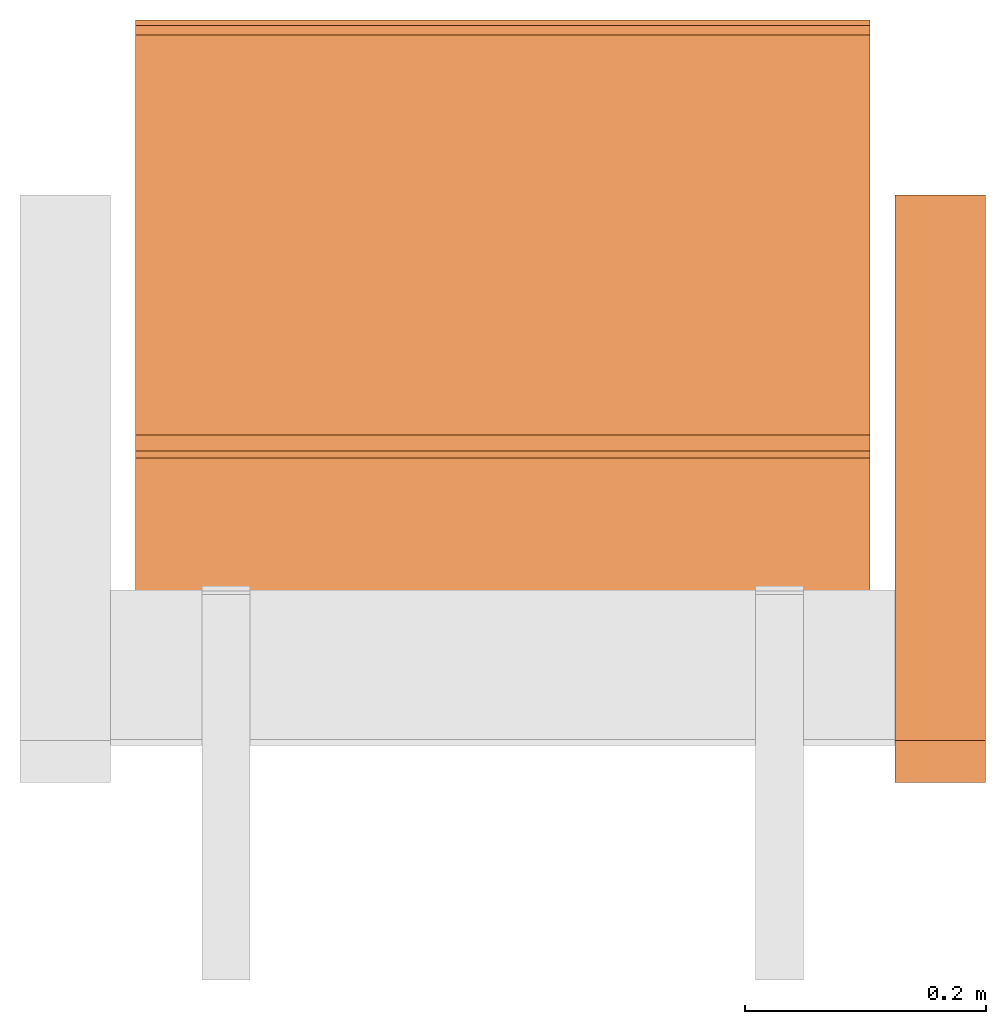
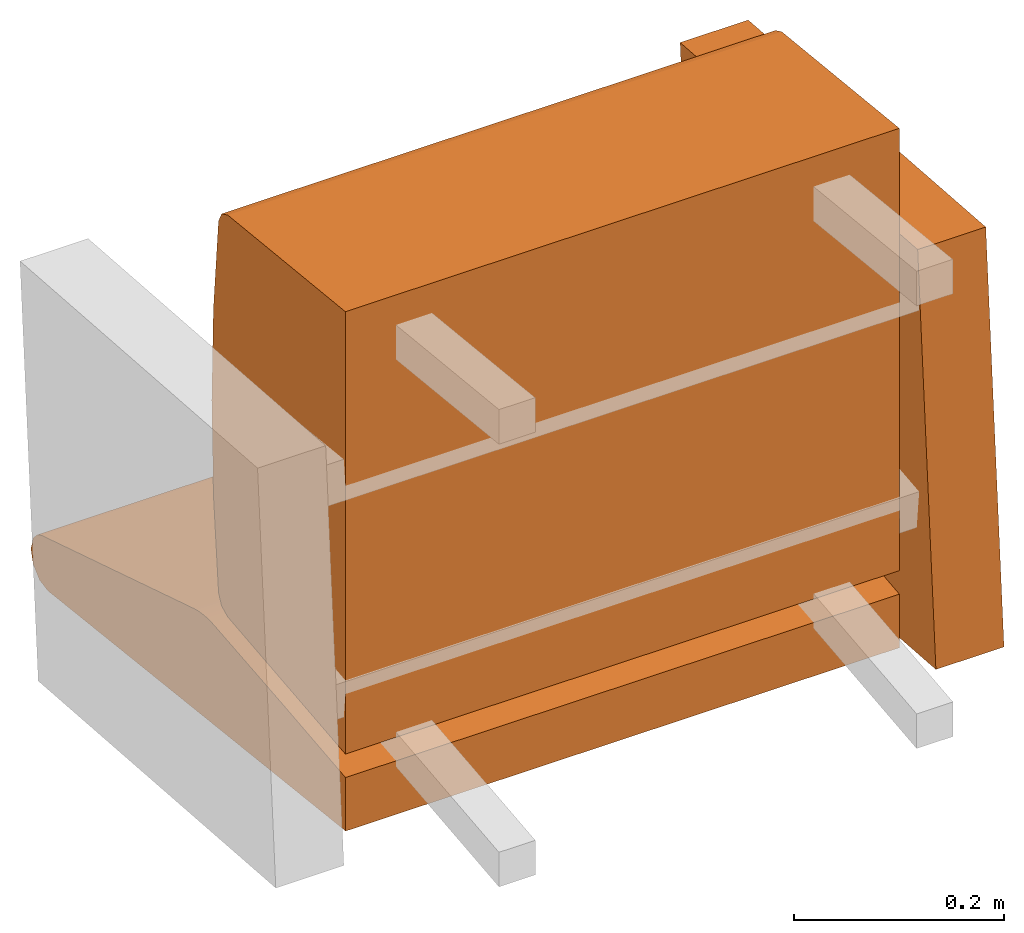
# One storey, part 1 of 2: 3 proxies, 1 element without a shape of its own.
"""IFC2X3 building model written with IfcOpenShell, lengths in metres."""

from ifc_helpers import new_model, si_unit, direction, origin_with_axes, place, context, project, spatial, faceted_brep, source, transform, mapped, element, aggregate, save


model = new_model("IFC2X3")

# Units and contexts
model_context = context("Model", 3, precision=1e-06, world=origin_with_axes(), true_north=direction((0.0, 1.0, 0.0)))
ifc_project = project(units=[si_unit("LENGTHUNIT", "METRE"), si_unit("AREAUNIT", "SQUARE_METRE"), si_unit("VOLUMEUNIT", "CUBIC_METRE")], contexts=[model_context])

# Site, building, storey
site_placement = place(None, origin_with_axes())
site = spatial("IfcSite", under=ifc_project, at=site_placement, CompositionType="ELEMENT")
building_placement = place(site_placement, origin_with_axes())
building = spatial("IfcBuilding", under=site, at=building_placement, Name="Default Building", CompositionType="ELEMENT")
storey_placement = place(building_placement, origin_with_axes())
storey = spatial("IfcBuildingStorey", under=building, at=storey_placement, Name="Default Storey", CompositionType="ELEMENT", Elevation=0.0)

# Assembly, proxies
assembly_placement = place(storey_placement, origin_with_axes())
assembly = element("IfcElementAssembly", 1, at=assembly_placement, inside=storey, Name="H-04-063-A_1-seater", ObjectType="H-04-063-A_1-seater", AssemblyPlace="NOTDEFINED", PredefinedType="NOTDEFINED")
shared_shape_1 = source(origin_with_axes(), model_context, "Body", "Brep", [
    faceted_brep([(0.3050000071525574, 0.14325888454914093, -0.2591053545475006), (0.3050000071525574, 0.1481551080942154, -0.25895237922668457), (-0.3050000071525574, 0.14325888454914093, -0.2591053545475006), (-0.3050000071525574, 0.14325888454914093, -0.2591053545475006), (0.3050000071525574, 0.1481551080942154, -0.25895237922668457), (-0.3050000071525574, 0.1481551080942154, -0.25895237922668457), (0.3050000071525574, 0.13837602734565735, -0.2594979405403137), (0.3050000071525574, 0.14325888454914093, -0.2591053545475006), (-0.3050000071525574, 0.13837602734565735, -0.2594979405403137), (-0.3050000071525574, 0.13837602734565735, -0.2594979405403137), (0.3050000071525574, 0.14325888454914093, -0.2591053545475006), (-0.3050000071525574, 0.14325888454914093, -0.2591053545475006), (0.3050000071525574, 0.01806718483567238, -0.27113938331604004), (0.3050000071525574, 0.13837602734565735, -0.2594979405403137), (-0.3050000071525574, 0.01806718483567238, -0.27113938331604004), (-0.3050000071525574, 0.01806718483567238, -0.27113938331604004), (0.3050000071525574, 0.13837602734565735, -0.2594979405403137), (-0.3050000071525574, 0.13837602734565735, -0.2594979405403137), (0.3050000071525574, -0.11122065782546997, -0.28472810983657837), (0.3050000071525574, 0.01806718483567238, -0.27113938331604004), (-0.3050000071525574, -0.11122065782546997, -0.28472810983657837), (-0.3050000071525574, -0.11122065782546997, -0.28472810983657837), (0.3050000071525574, 0.01806718483567238, -0.27113938331604004), (-0.3050000071525574, 0.01806718483567238, -0.27113938331604004), (0.3050000071525574, -0.11149738729000092, -0.34173157811164856), (0.3050000071525574, -0.11122065782546997, -0.28472810983657837), (-0.3050000071525574, -0.11149738729000092, -0.34173157811164856), (-0.3050000071525574, -0.11149738729000092, -0.34173157811164856), (0.3050000071525574, -0.11122065782546997, -0.28472810983657837), (-0.3050000071525574, -0.11122065782546997, -0.28472810983657837), (0.3050000071525574, -0.11152229458093643, -0.34686172008514404), (0.3050000071525574, -0.11149738729000092, -0.34173157811164856), (-0.3050000071525574, -0.11152229458093643, -0.34686172008514404), (-0.3050000071525574, -0.11152229458093643, -0.34686172008514404), (0.3050000071525574, -0.11149738729000092, -0.34173157811164856), (-0.3050000071525574, -0.11149738729000092, -0.34173157811164856), (0.3050000071525574, 0.45688581466674805, -0.41162365674972534), (0.3050000071525574, -0.11152229458093643, -0.34686172008514404), (-0.3050000071525574, 0.45688581466674805, -0.41162365674972534), (-0.3050000071525574, 0.45688581466674805, -0.41162365674972534), (0.3050000071525574, -0.11152229458093643, -0.34686172008514404), (-0.3050000071525574, -0.11152229458093643, -0.34686172008514404), (0.3050000071525574, 0.47266271710395813, -0.4085805416107178), (0.3050000071525574, 0.45688581466674805, -0.41162365674972534), (-0.3050000071525574, 0.47266271710395813, -0.4085805416107178), (-0.3050000071525574, 0.47266271710395813, -0.4085805416107178), (0.3050000071525574, 0.45688581466674805, -0.41162365674972534), (-0.3050000071525574, 0.45688581466674805, -0.41162365674972534), (0.3050000071525574, 0.48450586199760437, -0.3977386951446533), (0.3050000071525574, 0.47266271710395813, -0.4085805416107178), (-0.3050000071525574, 0.48450586199760437, -0.3977386951446533), (-0.3050000071525574, 0.48450586199760437, -0.3977386951446533), (0.3050000071525574, 0.47266271710395813, -0.4085805416107178), (-0.3050000071525574, 0.47266271710395813, -0.4085805416107178), (0.3050000071525574, 0.4888891279697418, -0.382292240858078), (0.3050000071525574, 0.48450586199760437, -0.3977386951446533), (-0.3050000071525574, 0.4888891279697418, -0.382292240858078), (-0.3050000071525574, 0.4888891279697418, -0.382292240858078), (0.3050000071525574, 0.48450586199760437, -0.3977386951446533), (-0.3050000071525574, 0.48450586199760437, -0.3977386951446533), (0.3050000071525574, 0.48450586199760437, -0.3668457865715027), (0.3050000071525574, 0.4888891279697418, -0.382292240858078), (-0.3050000071525574, 0.48450586199760437, -0.3668457865715027), (-0.3050000071525574, 0.48450586199760437, -0.3668457865715027), (0.3050000071525574, 0.4888891279697418, -0.382292240858078), (-0.3050000071525574, 0.4888891279697418, -0.382292240858078), (0.3050000071525574, 0.48142513632774353, -0.36358898878097534), (0.3050000071525574, 0.48450586199760437, -0.3668457865715027), (-0.3050000071525574, 0.48142513632774353, -0.36358898878097534), (-0.3050000071525574, 0.48142513632774353, -0.36358898878097534), (0.3050000071525574, 0.48450586199760437, -0.3668457865715027), (-0.3050000071525574, 0.48450586199760437, -0.3668457865715027), (0.3050000071525574, 0.47629326581954956, -0.3581638038158417), (0.3050000071525574, 0.48142513632774353, -0.36358898878097534), (-0.3050000071525574, 0.47629326581954956, -0.3581638038158417), (-0.3050000071525574, 0.47629326581954956, -0.3581638038158417), (0.3050000071525574, 0.48142513632774353, -0.36358898878097534), (-0.3050000071525574, 0.48142513632774353, -0.36358898878097534), (0.3050000071525574, 0.46827244758605957, -0.3542290925979614), (0.3050000071525574, 0.47629326581954956, -0.3581638038158417), (-0.3050000071525574, 0.46827244758605957, -0.3542290925979614), (-0.3050000071525574, 0.46827244758605957, -0.3542290925979614), (0.3050000071525574, 0.47629326581954956, -0.3581638038158417), (-0.3050000071525574, 0.47629326581954956, -0.3581638038158417), (0.3050000071525574, 0.17872300744056702, -0.2635229825973511), (0.3050000071525574, 0.46827244758605957, -0.3542290925979614), (-0.3050000071525574, 0.17872300744056702, -0.2635229825973511), (-0.3050000071525574, 0.17872300744056702, -0.2635229825973511), (0.3050000071525574, 0.46827244758605957, -0.3542290925979614), (-0.3050000071525574, 0.46827244758605957, -0.3542290925979614), (0.3050000071525574, 0.1771564930677414, -0.2630462944507599), (0.3050000071525574, 0.17872300744056702, -0.2635229825973511), (-0.3050000071525574, 0.1771564930677414, -0.2630462944507599), (-0.3050000071525574, 0.1771564930677414, -0.2630462944507599), (0.3050000071525574, 0.17872300744056702, -0.2635229825973511), (-0.3050000071525574, 0.17872300744056702, -0.2635229825973511), (0.3050000071525574, 0.17242595553398132, -0.26177409291267395), (0.3050000071525574, 0.1771564930677414, -0.2630462944507599), (-0.3050000071525574, 0.17242595553398132, -0.26177409291267395), (-0.3050000071525574, 0.17242595553398132, -0.26177409291267395), (0.3050000071525574, 0.1771564930677414, -0.2630462944507599), (-0.3050000071525574, 0.1771564930677414, -0.2630462944507599), (0.3050000071525574, 0.16763879358768463, -0.2607351243495941), (0.3050000071525574, 0.17242595553398132, -0.26177409291267395), (-0.3050000071525574, 0.16763879358768463, -0.2607351243495941), (-0.3050000071525574, 0.16763879358768463, -0.2607351243495941), (0.3050000071525574, 0.17242595553398132, -0.26177409291267395), (-0.3050000071525574, 0.17242595553398132, -0.26177409291267395), (0.3050000071525574, 0.16280649602413177, -0.2599318027496338), (0.3050000071525574, 0.16763879358768463, -0.2607351243495941), (-0.3050000071525574, 0.16280649602413177, -0.2599318027496338), (-0.3050000071525574, 0.16280649602413177, -0.2599318027496338), (0.3050000071525574, 0.16763879358768463, -0.2607351243495941), (-0.3050000071525574, 0.16763879358768463, -0.2607351243495941), (0.3050000071525574, 0.15794065594673157, -0.25936612486839294), (0.3050000071525574, 0.16280649602413177, -0.2599318027496338), (-0.3050000071525574, 0.15794065594673157, -0.25936612486839294), (-0.3050000071525574, 0.15794065594673157, -0.25936612486839294), (0.3050000071525574, 0.16280649602413177, -0.2599318027496338), (-0.3050000071525574, 0.16280649602413177, -0.2599318027496338), (0.3050000071525574, 0.15305295586585999, -0.25903937220573425), (0.3050000071525574, 0.15794065594673157, -0.25936612486839294), (-0.3050000071525574, 0.15305295586585999, -0.25903937220573425), (-0.3050000071525574, 0.15305295586585999, -0.25903937220573425), (0.3050000071525574, 0.15794065594673157, -0.25936612486839294), (-0.3050000071525574, 0.15794065594673157, -0.25936612486839294), (0.3050000071525574, 0.1481551080942154, -0.25895237922668457), (0.3050000071525574, 0.15305295586585999, -0.25903937220573425), (-0.3050000071525574, 0.1481551080942154, -0.25895237922668457), (-0.3050000071525574, 0.1481551080942154, -0.25895237922668457), (0.3050000071525574, 0.15305295586585999, -0.25903937220573425), (-0.3050000071525574, 0.15305295586585999, -0.25903937220573425), (0.3050000071525574, 0.48450586199760437, -0.3977386951446533), (0.3050000071525574, 0.4888891279697418, -0.382292240858078), (0.3050000071525574, 0.47266271710395813, -0.4085805416107178), (0.3050000071525574, 0.47266271710395813, -0.4085805416107178), (0.3050000071525574, 0.4888891279697418, -0.382292240858078), (0.3050000071525574, 0.48450586199760437, -0.3668457865715027), (0.3050000071525574, 0.47266271710395813, -0.4085805416107178), (0.3050000071525574, 0.48450586199760437, -0.3668457865715027), (0.3050000071525574, 0.45688581466674805, -0.41162365674972534), (0.3050000071525574, 0.45688581466674805, -0.41162365674972534), (0.3050000071525574, 0.48450586199760437, -0.3668457865715027), (0.3050000071525574, 0.48142513632774353, -0.36358898878097534), (0.3050000071525574, 0.14325888454914093, -0.2591053545475006), (0.3050000071525574, 0.13837602734565735, -0.2594979405403137), (0.3050000071525574, -0.11149738729000092, -0.34173157811164856), (0.3050000071525574, -0.11149738729000092, -0.34173157811164856), (0.3050000071525574, 0.13837602734565735, -0.2594979405403137), (0.3050000071525574, 0.01806718483567238, -0.27113938331604004), (0.3050000071525574, -0.11149738729000092, -0.34173157811164856), (0.3050000071525574, 0.01806718483567238, -0.27113938331604004), (0.3050000071525574, -0.11122065782546997, -0.28472810983657837), (0.3050000071525574, -0.11149738729000092, -0.34173157811164856), (0.3050000071525574, -0.11152229458093643, -0.34686172008514404), (0.3050000071525574, 0.46827244758605957, -0.3542290925979614), (0.3050000071525574, 0.46827244758605957, -0.3542290925979614), (0.3050000071525574, -0.11152229458093643, -0.34686172008514404), (0.3050000071525574, 0.45688581466674805, -0.41162365674972534), (0.3050000071525574, 0.46827244758605957, -0.3542290925979614), (0.3050000071525574, 0.45688581466674805, -0.41162365674972534), (0.3050000071525574, 0.47629326581954956, -0.3581638038158417), (0.3050000071525574, 0.47629326581954956, -0.3581638038158417), (0.3050000071525574, 0.45688581466674805, -0.41162365674972534), (0.3050000071525574, 0.48142513632774353, -0.36358898878097534), (0.3050000071525574, 0.46827244758605957, -0.3542290925979614), (0.3050000071525574, 0.17872300744056702, -0.2635229825973511), (0.3050000071525574, -0.11149738729000092, -0.34173157811164856), (0.3050000071525574, -0.11149738729000092, -0.34173157811164856), (0.3050000071525574, 0.17872300744056702, -0.2635229825973511), (0.3050000071525574, 0.1771564930677414, -0.2630462944507599), (0.3050000071525574, -0.11149738729000092, -0.34173157811164856), (0.3050000071525574, 0.1771564930677414, -0.2630462944507599), (0.3050000071525574, 0.17242595553398132, -0.26177409291267395), (0.3050000071525574, 0.17242595553398132, -0.26177409291267395), (0.3050000071525574, 0.16763879358768463, -0.2607351243495941), (0.3050000071525574, -0.11149738729000092, -0.34173157811164856), (0.3050000071525574, -0.11149738729000092, -0.34173157811164856), (0.3050000071525574, 0.16763879358768463, -0.2607351243495941), (0.3050000071525574, 0.16280649602413177, -0.2599318027496338), (0.3050000071525574, -0.11149738729000092, -0.34173157811164856), (0.3050000071525574, 0.16280649602413177, -0.2599318027496338), (0.3050000071525574, 0.15794065594673157, -0.25936612486839294), (0.3050000071525574, 0.15794065594673157, -0.25936612486839294), (0.3050000071525574, 0.15305295586585999, -0.25903937220573425), (0.3050000071525574, -0.11149738729000092, -0.34173157811164856), (0.3050000071525574, -0.11149738729000092, -0.34173157811164856), (0.3050000071525574, 0.15305295586585999, -0.25903937220573425), (0.3050000071525574, 0.1481551080942154, -0.25895237922668457), (0.3050000071525574, -0.11149738729000092, -0.34173157811164856), (0.3050000071525574, 0.1481551080942154, -0.25895237922668457), (0.3050000071525574, 0.14325888454914093, -0.2591053545475006), (-0.3050000071525574, 0.48450586199760437, -0.3668457865715027), (-0.3050000071525574, 0.4888891279697418, -0.382292240858078), (-0.3050000071525574, 0.48450586199760437, -0.3977386951446533), (-0.3050000071525574, 0.47629326581954956, -0.3581638038158417), (-0.3050000071525574, 0.45688581466674805, -0.41162365674972534), (-0.3050000071525574, 0.46827244758605957, -0.3542290925979614), (-0.3050000071525574, 0.46827244758605957, -0.3542290925979614), (-0.3050000071525574, 0.45688581466674805, -0.41162365674972534), (-0.3050000071525574, -0.11152229458093643, -0.34686172008514404), (-0.3050000071525574, 0.46827244758605957, -0.3542290925979614), (-0.3050000071525574, -0.11152229458093643, -0.34686172008514404), (-0.3050000071525574, -0.11149738729000092, -0.34173157811164856), (-0.3050000071525574, 0.47629326581954956, -0.3581638038158417), (-0.3050000071525574, 0.48142513632774353, -0.36358898878097534), (-0.3050000071525574, 0.45688581466674805, -0.41162365674972534), (-0.3050000071525574, 0.45688581466674805, -0.41162365674972534), (-0.3050000071525574, 0.48142513632774353, -0.36358898878097534), (-0.3050000071525574, 0.48450586199760437, -0.3668457865715027), (-0.3050000071525574, 0.45688581466674805, -0.41162365674972534), (-0.3050000071525574, 0.48450586199760437, -0.3668457865715027), (-0.3050000071525574, 0.47266271710395813, -0.4085805416107178), (-0.3050000071525574, 0.47266271710395813, -0.4085805416107178), (-0.3050000071525574, 0.48450586199760437, -0.3668457865715027), (-0.3050000071525574, 0.48450586199760437, -0.3977386951446533), (-0.3050000071525574, 0.17242595553398132, -0.26177409291267395), (-0.3050000071525574, 0.1771564930677414, -0.2630462944507599), (-0.3050000071525574, -0.11149738729000092, -0.34173157811164856), (-0.3050000071525574, -0.11149738729000092, -0.34173157811164856), (-0.3050000071525574, 0.1771564930677414, -0.2630462944507599), (-0.3050000071525574, 0.17872300744056702, -0.2635229825973511), (-0.3050000071525574, -0.11149738729000092, -0.34173157811164856), (-0.3050000071525574, 0.17872300744056702, -0.2635229825973511), (-0.3050000071525574, 0.46827244758605957, -0.3542290925979614), (-0.3050000071525574, -0.11122065782546997, -0.28472810983657837), (-0.3050000071525574, 0.01806718483567238, -0.27113938331604004), (-0.3050000071525574, -0.11149738729000092, -0.34173157811164856), (-0.3050000071525574, -0.11149738729000092, -0.34173157811164856), (-0.3050000071525574, 0.01806718483567238, -0.27113938331604004), (-0.3050000071525574, 0.13837602734565735, -0.2594979405403137), (-0.3050000071525574, -0.11149738729000092, -0.34173157811164856), (-0.3050000071525574, 0.13837602734565735, -0.2594979405403137), (-0.3050000071525574, 0.14325888454914093, -0.2591053545475006), (-0.3050000071525574, 0.14325888454914093, -0.2591053545475006), (-0.3050000071525574, 0.1481551080942154, -0.25895237922668457), (-0.3050000071525574, -0.11149738729000092, -0.34173157811164856), (-0.3050000071525574, -0.11149738729000092, -0.34173157811164856), (-0.3050000071525574, 0.1481551080942154, -0.25895237922668457), (-0.3050000071525574, 0.15305295586585999, -0.25903937220573425), (-0.3050000071525574, -0.11149738729000092, -0.34173157811164856), (-0.3050000071525574, 0.15305295586585999, -0.25903937220573425), (-0.3050000071525574, 0.15794065594673157, -0.25936612486839294), (-0.3050000071525574, 0.15794065594673157, -0.25936612486839294), (-0.3050000071525574, 0.16280649602413177, -0.2599318027496338), (-0.3050000071525574, -0.11149738729000092, -0.34173157811164856), (-0.3050000071525574, -0.11149738729000092, -0.34173157811164856), (-0.3050000071525574, 0.16280649602413177, -0.2599318027496338), (-0.3050000071525574, 0.16763879358768463, -0.2607351243495941), (-0.3050000071525574, -0.11149738729000092, -0.34173157811164856), (-0.3050000071525574, 0.16763879358768463, -0.2607351243495941), (-0.3050000071525574, 0.17242595553398132, -0.26177409291267395)], [[[0, 1, 2]], [[3, 4, 5]], [[6, 7, 8]], [[9, 10, 11]], [[12, 13, 14]], [[15, 16, 17]], [[18, 19, 20]], [[21, 22, 23]], [[24, 25, 26]], [[27, 28, 29]], [[30, 31, 32]], [[33, 34, 35]], [[36, 37, 38]], [[39, 40, 41]], [[42, 43, 44]], [[45, 46, 47]], [[48, 49, 50]], [[51, 52, 53]], [[54, 55, 56]], [[57, 58, 59]], [[60, 61, 62]], [[63, 64, 65]], [[66, 67, 68]], [[69, 70, 71]], [[72, 73, 74]], [[75, 76, 77]], [[78, 79, 80]], [[81, 82, 83]], [[84, 85, 86]], [[87, 88, 89]], [[90, 91, 92]], [[93, 94, 95]], [[96, 97, 98]], [[99, 100, 101]], [[102, 103, 104]], [[105, 106, 107]], [[108, 109, 110]], [[111, 112, 113]], [[114, 115, 116]], [[117, 118, 119]], [[120, 121, 122]], [[123, 124, 125]], [[126, 127, 128]], [[129, 130, 131]], [[132, 133, 134]], [[135, 136, 137]], [[138, 139, 140]], [[141, 142, 143]], [[144, 145, 146]], [[147, 148, 149]], [[150, 151, 152]], [[153, 154, 155]], [[156, 157, 158]], [[159, 160, 161]], [[162, 163, 164]], [[165, 166, 167]], [[168, 169, 170]], [[171, 172, 173]], [[174, 175, 176]], [[177, 178, 179]], [[180, 181, 182]], [[183, 184, 185]], [[186, 187, 188]], [[189, 190, 191]], [[192, 193, 194]], [[195, 196, 197]], [[198, 199, 200]], [[201, 202, 203]], [[204, 205, 206]], [[207, 208, 209]], [[210, 211, 212]], [[213, 214, 215]], [[216, 217, 218]], [[219, 220, 221]], [[222, 223, 224]], [[225, 226, 227]], [[228, 229, 230]], [[231, 232, 233]], [[234, 235, 236]], [[237, 238, 239]], [[240, 241, 242]], [[243, 244, 245]], [[246, 247, 248]], [[249, 250, 251]]]),
])
proxy_1_placement = place(assembly_placement, origin_with_axes())
proxy_1 = element("IfcBuildingElementProxy", 2, at=proxy_1_placement, Name="1", ObjectType="1", CompositionType="ELEMENT", context=model_context, shape_type="MappedRepresentation", body=[
    mapped(shared_shape_1, transform((0.0, 0.0, 0.0), scale=1.0)),
])
shared_shape_2 = source(origin_with_axes(), model_context, "Body", "Brep", [
    faceted_brep([(0.32600000500679016, -0.10966596007347107, 0.10816171765327454), (0.32600000500679016, 0.34345003962516785, 0.07445737719535828), (0.32600000500679016, -0.1444617062807083, -0.35962703824043274), (0.32600000500679016, -0.1444617062807083, -0.35962703824043274), (0.32600000500679016, 0.34345003962516785, 0.07445737719535828), (0.32600000500679016, 0.3086542785167694, -0.393331378698349), (0.4009999930858612, -0.10966596007347107, 0.10816171765327454), (0.32600000500679016, -0.10966596007347107, 0.10816171765327454), (0.4009999930858612, -0.1444617062807083, -0.35962703824043274), (0.4009999930858612, -0.1444617062807083, -0.35962703824043274), (0.32600000500679016, -0.10966596007347107, 0.10816171765327454), (0.32600000500679016, -0.1444617062807083, -0.35962703824043274), (0.4009999930858612, 0.34345003962516785, 0.07445737719535828), (0.4009999930858612, -0.10966596007347107, 0.10816171765327454), (0.4009999930858612, 0.3086542785167694, -0.393331378698349), (0.4009999930858612, 0.3086542785167694, -0.393331378698349), (0.4009999930858612, -0.10966596007347107, 0.10816171765327454), (0.4009999930858612, -0.1444617062807083, -0.35962703824043274), (0.32600000500679016, 0.34345003962516785, 0.07445737719535828), (0.4009999930858612, 0.34345003962516785, 0.07445737719535828), (0.32600000500679016, 0.3086542785167694, -0.393331378698349), (0.32600000500679016, 0.3086542785167694, -0.393331378698349), (0.4009999930858612, 0.34345003962516785, 0.07445737719535828), (0.4009999930858612, 0.3086542785167694, -0.393331378698349), (0.4009999930858612, -0.10966596007347107, 0.10816171765327454), (0.4009999930858612, 0.34345003962516785, 0.07445737719535828), (0.32600000500679016, -0.10966596007347107, 0.10816171765327454), (0.32600000500679016, -0.10966596007347107, 0.10816171765327454), (0.4009999930858612, 0.34345003962516785, 0.07445737719535828), (0.32600000500679016, 0.34345003962516785, 0.07445737719535828), (0.4009999930858612, 0.3086542785167694, -0.393331378698349), (0.4009999930858612, -0.1444617062807083, -0.35962703824043274), (0.32600000500679016, 0.3086542785167694, -0.393331378698349), (0.32600000500679016, 0.3086542785167694, -0.393331378698349), (0.4009999930858612, -0.1444617062807083, -0.35962703824043274), (0.32600000500679016, -0.1444617062807083, -0.35962703824043274)], [[[0, 1, 2]], [[3, 4, 5]], [[6, 7, 8]], [[9, 10, 11]], [[12, 13, 14]], [[15, 16, 17]], [[18, 19, 20]], [[21, 22, 23]], [[24, 25, 26]], [[27, 28, 29]], [[30, 31, 32]], [[33, 34, 35]]]),
])
proxy_2_placement = place(assembly_placement, origin_with_axes())
proxy_2 = element("IfcBuildingElementProxy", 3, at=proxy_2_placement, Name="2", ObjectType="2", CompositionType="ELEMENT", context=model_context, shape_type="MappedRepresentation", body=[
    mapped(shared_shape_2, transform((0.0, 0.0, 0.0), scale=1.0)),
])
shared_shape_3 = source(origin_with_axes(), model_context, "Body", "Brep", [
    faceted_brep([(0.3050000071525574, -0.11101193726062775, -0.25744837522506714), (0.3050000071525574, -0.11100000143051147, 0.25755399465560913), (-0.3050000071525574, -0.11101193726062775, -0.25744837522506714), (-0.3050000071525574, -0.11101193726062775, -0.25744837522506714), (0.3050000071525574, -0.11100000143051147, 0.25755399465560913), (-0.3050000071525574, -0.11100000143051147, 0.25755399465560913), (0.3050000071525574, 0.11316553503274918, -0.23389163613319397), (0.3050000071525574, -0.11101193726062775, -0.25744837522506714), (-0.3050000071525574, 0.11316553503274918, -0.23389163613319397), (-0.3050000071525574, 0.11316553503274918, -0.23389163613319397), (0.3050000071525574, -0.11101193726062775, -0.25744837522506714), (-0.3050000071525574, -0.11101193726062775, -0.25744837522506714), (0.3050000071525574, 0.12510773539543152, -0.22825226187705994), (0.3050000071525574, 0.11316553503274918, -0.23389163613319397), (-0.3050000071525574, 0.12510773539543152, -0.22825226187705994), (-0.3050000071525574, 0.12510773539543152, -0.22825226187705994), (0.3050000071525574, 0.11316553503274918, -0.23389163613319397), (-0.3050000071525574, 0.11316553503274918, -0.23389163613319397), (0.3050000071525574, 0.13093119859695435, -0.21639873087406158), (0.3050000071525574, 0.12510773539543152, -0.22825226187705994), (-0.3050000071525574, 0.13093119859695435, -0.21639873087406158), (-0.3050000071525574, 0.13093119859695435, -0.21639873087406158), (0.3050000071525574, 0.12510773539543152, -0.22825226187705994), (-0.3050000071525574, 0.12510773539543152, -0.22825226187705994), (0.3050000071525574, 0.14069734513759613, -0.10837350785732269), (0.3050000071525574, 0.13093119859695435, -0.21639873087406158), (-0.3050000071525574, 0.14069734513759613, -0.10837350785732269), (-0.3050000071525574, 0.14069734513759613, -0.10837350785732269), (0.3050000071525574, 0.13093119859695435, -0.21639873087406158), (-0.3050000071525574, 0.13093119859695435, -0.21639873087406158), (0.3050000071525574, 0.14396685361862183, 4.298765634302981e-05), (0.3050000071525574, 0.14069734513759613, -0.10837350785732269), (-0.3050000071525574, 0.14396685361862183, 4.298765634302981e-05), (-0.3050000071525574, 0.14396685361862183, 4.298765634302981e-05), (0.3050000071525574, 0.14069734513759613, -0.10837350785732269), (-0.3050000071525574, 0.14069734513759613, -0.10837350785732269), (0.3050000071525574, 0.1407279372215271, 0.10846040397882462), (0.3050000071525574, 0.14396685361862183, 4.298765634302981e-05), (-0.3050000071525574, 0.1407279372215271, 0.10846040397882462), (-0.3050000071525574, 0.1407279372215271, 0.10846040397882462), (0.3050000071525574, 0.14396685361862183, 4.298765634302981e-05), (-0.3050000071525574, 0.14396685361862183, 4.298765634302981e-05), (0.3050000071525574, 0.13099226355552673, 0.21648837625980377), (0.3050000071525574, 0.1407279372215271, 0.10846040397882462), (-0.3050000071525574, 0.13099226355552673, 0.21648837625980377), (-0.3050000071525574, 0.13099226355552673, 0.21648837625980377), (0.3050000071525574, 0.1407279372215271, 0.10846040397882462), (-0.3050000071525574, 0.1407279372215271, 0.10846040397882462), (0.3050000071525574, 0.12517030537128448, 0.2283453643321991), (0.3050000071525574, 0.13099226355552673, 0.21648837625980377), (-0.3050000071525574, 0.12517030537128448, 0.2283453643321991), (-0.3050000071525574, 0.12517030537128448, 0.2283453643321991), (0.3050000071525574, 0.13099226355552673, 0.21648837625980377), (-0.3050000071525574, 0.13099226355552673, 0.21648837625980377), (0.3050000071525574, 0.11322638392448425, 0.23398683965206146), (0.3050000071525574, 0.12517030537128448, 0.2283453643321991), (-0.3050000071525574, 0.11322638392448425, 0.23398683965206146), (-0.3050000071525574, 0.11322638392448425, 0.23398683965206146), (0.3050000071525574, 0.12517030537128448, 0.2283453643321991), (-0.3050000071525574, 0.12517030537128448, 0.2283453643321991), (0.3050000071525574, -0.11100000143051147, 0.25755399465560913), (0.3050000071525574, 0.11322638392448425, 0.23398683965206146), (-0.3050000071525574, -0.11100000143051147, 0.25755399465560913), (-0.3050000071525574, -0.11100000143051147, 0.25755399465560913), (0.3050000071525574, 0.11322638392448425, 0.23398683965206146), (-0.3050000071525574, 0.11322638392448425, 0.23398683965206146), (0.3050000071525574, 0.13099226355552673, 0.21648837625980377), (0.3050000071525574, 0.12517030537128448, 0.2283453643321991), (0.3050000071525574, 0.1407279372215271, 0.10846040397882462), (0.3050000071525574, 0.1407279372215271, 0.10846040397882462), (0.3050000071525574, 0.12517030537128448, 0.2283453643321991), (0.3050000071525574, 0.11322638392448425, 0.23398683965206146), (0.3050000071525574, 0.1407279372215271, 0.10846040397882462), (0.3050000071525574, 0.11322638392448425, 0.23398683965206146), (0.3050000071525574, -0.11100000143051147, 0.25755399465560913), (0.3050000071525574, 0.12510773539543152, -0.22825226187705994), (0.3050000071525574, 0.13093119859695435, -0.21639873087406158), (0.3050000071525574, 0.11316553503274918, -0.23389163613319397), (0.3050000071525574, 0.11316553503274918, -0.23389163613319397), (0.3050000071525574, 0.13093119859695435, -0.21639873087406158), (0.3050000071525574, 0.14069734513759613, -0.10837350785732269), (0.3050000071525574, 0.11316553503274918, -0.23389163613319397), (0.3050000071525574, 0.14069734513759613, -0.10837350785732269), (0.3050000071525574, -0.11101193726062775, -0.25744837522506714), (0.3050000071525574, -0.11101193726062775, -0.25744837522506714), (0.3050000071525574, 0.14069734513759613, -0.10837350785732269), (0.3050000071525574, -0.11100000143051147, 0.25755399465560913), (0.3050000071525574, -0.11100000143051147, 0.25755399465560913), (0.3050000071525574, 0.14069734513759613, -0.10837350785732269), (0.3050000071525574, 0.14396685361862183, 4.298765634302981e-05), (0.3050000071525574, -0.11100000143051147, 0.25755399465560913), (0.3050000071525574, 0.14396685361862183, 4.298765634302981e-05), (0.3050000071525574, 0.1407279372215271, 0.10846040397882462), (-0.3050000071525574, 0.14069734513759613, -0.10837350785732269), (-0.3050000071525574, 0.13093119859695435, -0.21639873087406158), (-0.3050000071525574, 0.12510773539543152, -0.22825226187705994), (-0.3050000071525574, 0.12517030537128448, 0.2283453643321991), (-0.3050000071525574, 0.13099226355552673, 0.21648837625980377), (-0.3050000071525574, 0.11322638392448425, 0.23398683965206146), (-0.3050000071525574, 0.11322638392448425, 0.23398683965206146), (-0.3050000071525574, 0.13099226355552673, 0.21648837625980377), (-0.3050000071525574, 0.1407279372215271, 0.10846040397882462), (-0.3050000071525574, 0.11322638392448425, 0.23398683965206146), (-0.3050000071525574, 0.1407279372215271, 0.10846040397882462), (-0.3050000071525574, -0.11100000143051147, 0.25755399465560913), (-0.3050000071525574, -0.11100000143051147, 0.25755399465560913), (-0.3050000071525574, 0.1407279372215271, 0.10846040397882462), (-0.3050000071525574, 0.14396685361862183, 4.298765634302981e-05), (-0.3050000071525574, -0.11100000143051147, 0.25755399465560913), (-0.3050000071525574, 0.14396685361862183, 4.298765634302981e-05), (-0.3050000071525574, -0.11101193726062775, -0.25744837522506714), (-0.3050000071525574, -0.11101193726062775, -0.25744837522506714), (-0.3050000071525574, 0.14396685361862183, 4.298765634302981e-05), (-0.3050000071525574, 0.14069734513759613, -0.10837350785732269), (-0.3050000071525574, -0.11101193726062775, -0.25744837522506714), (-0.3050000071525574, 0.14069734513759613, -0.10837350785732269), (-0.3050000071525574, 0.11316553503274918, -0.23389163613319397), (-0.3050000071525574, 0.11316553503274918, -0.23389163613319397), (-0.3050000071525574, 0.14069734513759613, -0.10837350785732269), (-0.3050000071525574, 0.12510773539543152, -0.22825226187705994)], [[[0, 1, 2]], [[3, 4, 5]], [[6, 7, 8]], [[9, 10, 11]], [[12, 13, 14]], [[15, 16, 17]], [[18, 19, 20]], [[21, 22, 23]], [[24, 25, 26]], [[27, 28, 29]], [[30, 31, 32]], [[33, 34, 35]], [[36, 37, 38]], [[39, 40, 41]], [[42, 43, 44]], [[45, 46, 47]], [[48, 49, 50]], [[51, 52, 53]], [[54, 55, 56]], [[57, 58, 59]], [[60, 61, 62]], [[63, 64, 65]], [[66, 67, 68]], [[69, 70, 71]], [[72, 73, 74]], [[75, 76, 77]], [[78, 79, 80]], [[81, 82, 83]], [[84, 85, 86]], [[87, 88, 89]], [[90, 91, 92]], [[93, 94, 95]], [[96, 97, 98]], [[99, 100, 101]], [[102, 103, 104]], [[105, 106, 107]], [[108, 109, 110]], [[111, 112, 113]], [[114, 115, 116]], [[117, 118, 119]]]),
])
proxy_3_placement = place(assembly_placement, origin_with_axes())
proxy_3 = element("IfcBuildingElementProxy", 4, at=proxy_3_placement, Name="3", ObjectType="3", CompositionType="ELEMENT", context=model_context, shape_type="MappedRepresentation", body=[
    mapped(shared_shape_3, transform((0.0, 0.0, 0.0), scale=1.0)),
])
aggregate(assembly, [proxy_1, proxy_2, proxy_3])

save(model, "model.ifc")
